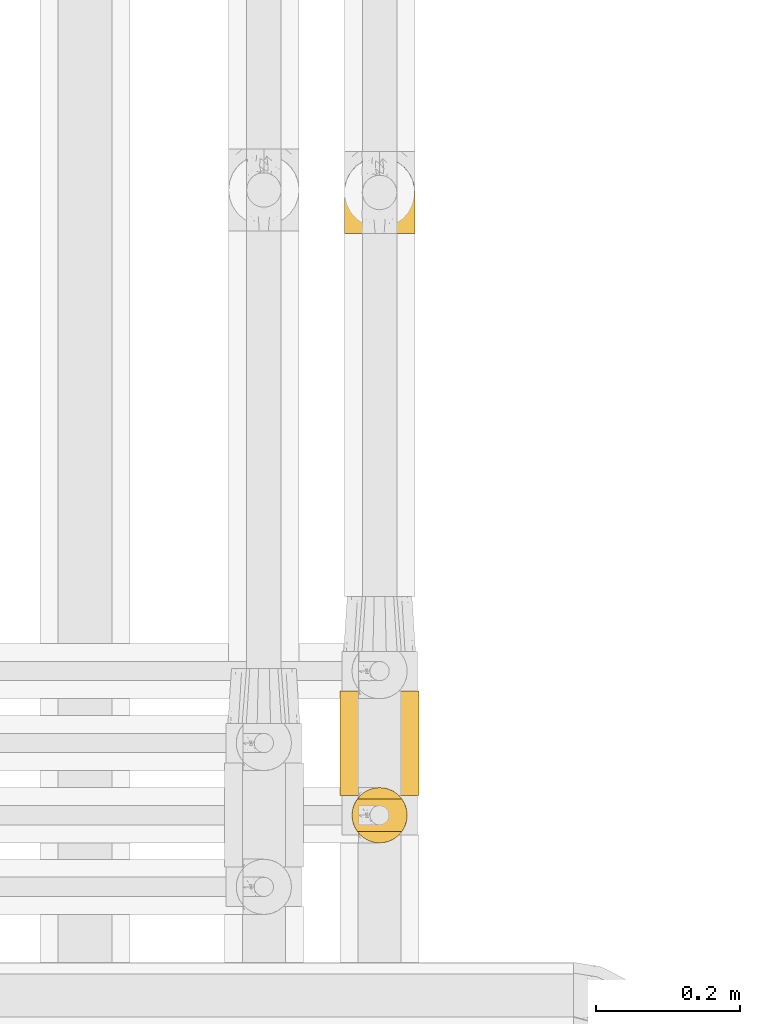
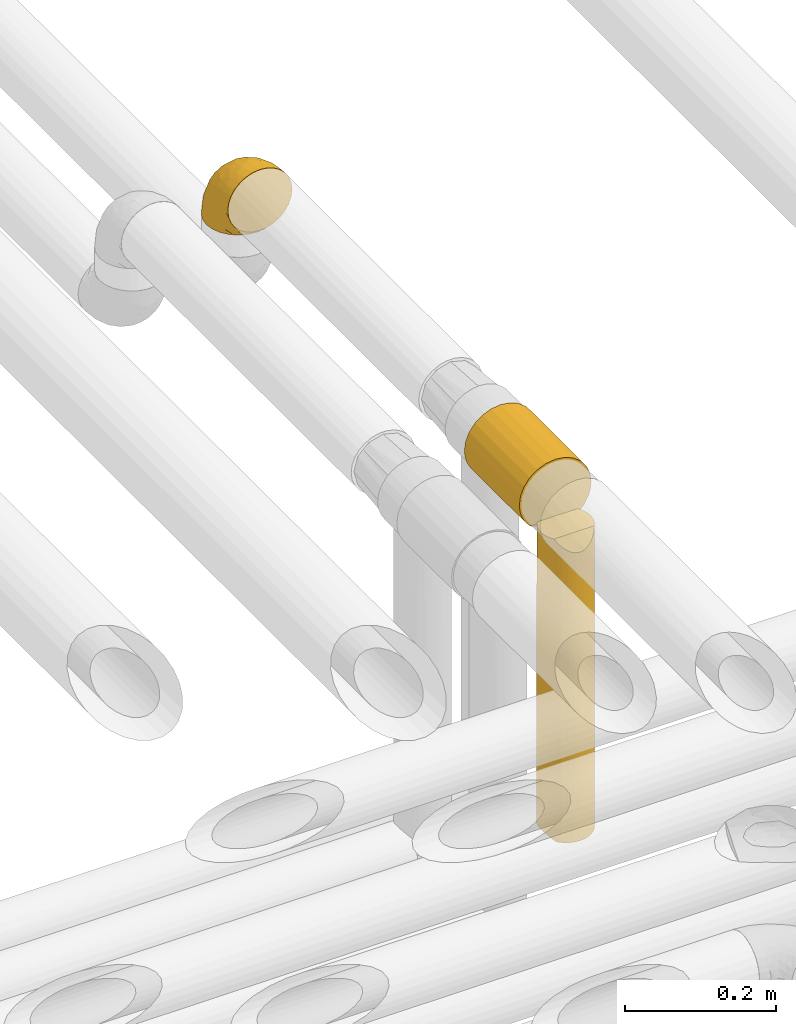
# One storey, part 347 of 827: 3 coverings.
"""IFC2X3 building model written with IfcOpenShell, lengths in millimetres."""

from ifc_helpers import new_model, entity, si_unit, converted_unit, derived_unit, direction, frame, origin, place, context, subcontext, project, spatial, faceted_brep, element, save


model = new_model("IFC2X3")

# Units and contexts
model_context = context("Model", 3, precision=0.01, world=origin(), true_north=direction((6.12303176911189e-17, 1.0)))
body_context = subcontext(model_context, "Body", "Model", "MODEL_VIEW")
ifc_project = project(units=[si_unit("LENGTHUNIT", "METRE", prefix="MILLI"), si_unit("AREAUNIT", "SQUARE_METRE"), si_unit("VOLUMEUNIT", "CUBIC_METRE"), converted_unit("PLANEANGLEUNIT", "DEGREE", entity("IfcRatioMeasure", 0.0174532925199433), si_unit("PLANEANGLEUNIT", "RADIAN"), dimensions=[0, 0, 0, 0, 0, 0, 0]), si_unit("MASSUNIT", "GRAM", prefix="KILO"), derived_unit("MASSDENSITYUNIT", [(si_unit("MASSUNIT", "GRAM", prefix="KILO"), 1), (si_unit("LENGTHUNIT", "METRE"), -3)]), derived_unit("MOMENTOFINERTIAUNIT", [(si_unit("LENGTHUNIT", "METRE"), 4)]), si_unit("TIMEUNIT", "SECOND"), si_unit("FREQUENCYUNIT", "HERTZ"), si_unit("THERMODYNAMICTEMPERATUREUNIT", "DEGREE_CELSIUS"), derived_unit("THERMALTRANSMITTANCEUNIT", [(si_unit("MASSUNIT", "GRAM", prefix="KILO"), 1), (si_unit("THERMODYNAMICTEMPERATUREUNIT", "KELVIN"), -1), (si_unit("TIMEUNIT", "SECOND"), -3)]), derived_unit("VOLUMETRICFLOWRATEUNIT", [(si_unit("LENGTHUNIT", "METRE"), 3), (si_unit("TIMEUNIT", "SECOND"), -1)]), derived_unit("MASSFLOWRATEUNIT", [(si_unit("MASSUNIT", "GRAM", prefix="KILO"), 1), (si_unit("TIMEUNIT", "SECOND"), -1)]), derived_unit("ROTATIONALFREQUENCYUNIT", [(si_unit("TIMEUNIT", "SECOND"), -1)]), si_unit("ELECTRICCURRENTUNIT", "AMPERE"), si_unit("ELECTRICVOLTAGEUNIT", "VOLT"), si_unit("POWERUNIT", "WATT"), si_unit("FORCEUNIT", "NEWTON", prefix="KILO"), si_unit("ILLUMINANCEUNIT", "LUX"), si_unit("LUMINOUSFLUXUNIT", "LUMEN"), si_unit("LUMINOUSINTENSITYUNIT", "CANDELA"), derived_unit("USERDEFINED", [(si_unit("MASSUNIT", "GRAM", prefix="KILO"), -1), (si_unit("LENGTHUNIT", "METRE"), -2), (si_unit("TIMEUNIT", "SECOND"), 3), (si_unit("LUMINOUSFLUXUNIT", "LUMEN"), 1)]), derived_unit("LINEARVELOCITYUNIT", [(si_unit("LENGTHUNIT", "METRE"), 1), (si_unit("TIMEUNIT", "SECOND"), -1)]), si_unit("PRESSUREUNIT", "PASCAL"), derived_unit("USERDEFINED", [(si_unit("LENGTHUNIT", "METRE"), -2), (si_unit("MASSUNIT", "GRAM", prefix="KILO"), 1), (si_unit("TIMEUNIT", "SECOND"), -2)]), derived_unit("LINEARFORCEUNIT", [(si_unit("MASSUNIT", "GRAM", prefix="KILO"), 1), (si_unit("LENGTHUNIT", "METRE"), 1), (si_unit("TIMEUNIT", "SECOND"), -2), (si_unit("LENGTHUNIT", "METRE"), -1)]), derived_unit("PLANARFORCEUNIT", [(si_unit("MASSUNIT", "GRAM", prefix="KILO"), 1), (si_unit("LENGTHUNIT", "METRE"), 1), (si_unit("TIMEUNIT", "SECOND"), -2), (si_unit("LENGTHUNIT", "METRE"), -2)])], contexts=[model_context])

# Site, building, storey
site_placement = place(None, origin())
site = spatial("IfcSite", under=ifc_project, at=site_placement, CompositionType="ELEMENT")
building_placement = place(site_placement, origin())
building = spatial("IfcBuilding", under=site, at=building_placement, CompositionType="ELEMENT")
storey_placement = place(building_placement, frame((0.0, 0.0, 28200.0)))
storey = spatial("IfcBuildingStorey", under=building, at=storey_placement, Name="08", CompositionType="ELEMENT", Elevation=28200.0)

# Coverings
covering_1_placement = place(storey_placement, frame((36578.9, 16196.89, 3491.4)))
element("IfcCovering", 1, at=covering_1_placement, inside=storey, Name=":ADSK_", ObjectType=":ADSK_", PredefinedType="INSULATION", context=body_context, shape_type="Brep", body=[
    faceted_brep([(99.9, 1.6, 58.6), (98.66, 1.6, 69.54), (95.02, 1.6, 79.93), (89.17, 1.6, 89.25), (81.38, 1.6, 97.03), (72.06, 1.6, 102.88), (61.68, 1.6, 106.51), (50.75, 1.6, 107.75), (39.8, 1.6, 106.51), (29.41, 1.6, 102.87), (20.09, 1.6, 97.02), (12.31, 1.6, 89.23), (6.46, 1.6, 79.91), (2.83, 1.6, 69.53), (1.6, 1.6, 58.6), (2.24, 1.6, 52.89), (2.83, 1.6, 47.65), (4.65, 1.6, 42.46), (6.47, 1.6, 37.26), (12.32, 1.6, 27.94), (20.11, 1.6, 20.16), (29.43, 1.6, 14.31), (39.81, 1.6, 10.68), (50.75, 1.6, 9.45), (61.69, 1.6, 10.68), (72.08, 1.6, 14.32), (81.4, 1.6, 20.17), (89.18, 1.6, 27.96), (95.03, 1.6, 37.28), (96.85, 1.6, 42.47), (98.66, 1.6, 47.66), (99.25, 1.6, 52.89), (99.57, 1.6, 55.75), (38.02, 11.12, 1.6), (26.17, 16.03, 1.6), (21.08, 19.94, 1.6), (15.99, 23.84, 1.6), (12.09, 28.93, 1.6), (8.18, 34.02, 1.6), (5.73, 39.95, 1.6), (3.27, 45.87, 1.6), (2.35, 52.86, 1.6), (1.97, 55.73, 1.6), (1.6, 58.6, 1.6), (3.27, 71.32, 1.6), (8.18, 83.17, 1.6), (15.99, 93.35, 1.6), (26.17, 101.16, 1.6), (38.02, 106.07, 1.6), (50.75, 107.75, 1.6), (63.47, 106.07, 1.6), (75.32, 101.16, 1.6), (85.5, 93.35, 1.6), (93.31, 83.17, 1.6), (98.22, 71.32, 1.6), (99.9, 58.6, 1.6), (99.14, 52.86, 1.6), (98.22, 45.87, 1.6), (95.77, 39.95, 1.6), (93.31, 34.02, 1.6), (89.4, 28.93, 1.6), (85.5, 23.84, 1.6), (80.41, 19.94, 1.6), (75.32, 16.03, 1.6), (63.47, 11.12, 1.6), (50.75, 9.45, 1.6), (59.31, 81.82, 69.96), (73.08, 84.02, 59.59), (63.72, 93.05, 51.96), (50.75, 102.55, 34.4), (58.64, 104.83, 23.37), (50.75, 105.83, 13.68), (76.74, 91.87, 41.52), (67.68, 101.74, 26.26), (78.92, 97.07, 20.18), (94.31, 38.45, 72.33), (98.76, 22.17, 65.88), (98.4, 42.04, 57.55), (94.57, 77.69, 23.76), (89.91, 75.76, 46.5), (96.32, 62.11, 46.57), (98.79, 66.08, 21.17), (99.9, 54.26, 23.41), (99.9, 55.35, 17.92), (99.9, 56.44, 12.43), (99.9, 56.98, 9.72), (99.9, 57.52, 7.01), (87.31, 87.84, 26.77), (95.61, 19.41, 76.59), (60.43, 48.89, 95.55), (65.24, 26.34, 102.57), (72.87, 44.55, 92.89), (99.9, 23.41, 54.26), (99.9, 28.03, 51.17), (99.9, 32.65, 48.08), (99.9, 37.28, 44.99), (99.9, 41.9, 41.9), (90.65, 20.6, 85.16), (63.14, 63.36, 85.97), (91.89, 62.21, 59.58), (75.25, 19.94, 99.5), (50.75, 13.68, 105.83), (82.18, 80.85, 53.59), (85.08, 66.53, 67.0), (76.93, 71.06, 71.56), (50.75, 63.99, 87.47), (50.75, 75.73, 75.73), (83.02, 26.77, 92.24), (99.9, 4.31, 58.06), (99.9, 7.01, 57.52), (99.9, 12.43, 56.44), (99.9, 17.92, 55.35), (87.13, 43.43, 81.33), (80.85, 56.23, 80.35), (99.17, 54.97, 39.44), (50.75, 34.4, 102.55), (99.9, 44.99, 37.28), (99.9, 48.08, 32.65), (99.9, 51.17, 28.03), (50.75, 87.47, 63.99), (67.61, 74.55, 74.55), (72.25, 60.86, 83.62), (50.75, 49.19, 95.01), (50.75, 95.01, 49.19), (98.69, 10.27, 46.96), (99.01, 48.79, 8.77), (98.79, 45.16, 18.28), (98.29, 44.99, 11.68), (68.51, 6.17, 11.79), (76.82, 7.65, 15.69), (98.54, 21.59, 42.49), (99.3, 19.96, 47.41), (83.57, 21.0, 7.94), (89.47, 27.2, 9.27), (75.76, 14.83, 7.98), (84.86, 19.7, 13.4), (75.89, 10.93, 13.04), (64.77, 9.63, 7.36), (90.83, 19.97, 23.46), (94.62, 21.13, 30.46), (90.37, 14.14, 26.54), (91.18, 30.2, 6.76), (88.65, 8.12, 26.46), (84.11, 9.93, 20.77), (91.75, 24.62, 20.68), (96.86, 11.87, 40.26), (50.75, 7.15, 7.15), (58.97, 5.32, 9.28), (98.37, 26.68, 38.78), (83.91, 13.92, 18.27), (97.52, 30.67, 31.78), (95.55, 36.65, 12.75), (98.76, 42.89, 22.96), (95.26, 34.04, 17.55), (98.04, 36.6, 27.63), (90.65, 26.41, 15.23), (93.51, 10.07, 33.25), (94.16, 15.83, 32.43), (99.1, 41.99, 27.9), (25.73, 14.83, 7.97), (10.84, 26.4, 15.22), (17.92, 21.01, 7.93), (16.64, 19.71, 13.38), (30.44, 5.72, 13.12), (2.95, 21.6, 42.49), (2.19, 19.96, 47.4), (1.6, 28.03, 51.17), (4.63, 11.87, 40.24), (17.39, 9.93, 20.76), (1.6, 58.06, 4.31), (1.6, 56.44, 12.43), (1.6, 57.52, 7.01), (12.86, 8.13, 26.44), (11.13, 14.15, 26.52), (3.2, 44.99, 11.68), (5.94, 36.65, 12.75), (12.02, 27.21, 9.27), (6.23, 34.04, 17.55), (10.31, 30.2, 6.76), (8.0, 10.06, 33.21), (7.34, 15.83, 32.41), (2.48, 48.79, 8.77), (2.73, 42.89, 22.96), (2.64, 45.38, 18.48), (1.6, 12.43, 56.44), (2.8, 10.28, 46.95), (36.71, 9.64, 7.36), (1.6, 55.35, 17.92), (1.6, 54.26, 23.41), (38.59, 6.05, 9.85), (1.6, 7.01, 57.52), (1.6, 9.72, 56.98), (1.6, 32.65, 48.08), (3.12, 26.68, 38.78), (17.59, 13.92, 18.25), (1.6, 37.28, 44.99), (3.98, 30.66, 31.74), (6.87, 21.14, 30.45), (3.45, 36.59, 27.63), (9.76, 24.6, 20.65), (1.6, 17.92, 55.35), (1.6, 23.41, 54.26), (25.62, 10.93, 13.03), (10.67, 19.97, 23.44), (2.39, 41.99, 27.9), (1.6, 48.08, 32.65), (1.6, 51.17, 28.03), (1.6, 44.99, 37.28), (1.6, 41.9, 41.9), (2.4, 55.26, 39.74), (42.85, 104.83, 23.37), (14.18, 87.84, 26.77), (11.56, 75.91, 46.18), (19.27, 80.84, 53.54), (24.75, 91.87, 41.53), (28.37, 83.98, 59.61), (5.95, 19.16, 76.79), (2.79, 22.37, 66.11), (2.71, 66.08, 21.17), (37.78, 93.05, 51.96), (33.81, 101.74, 26.26), (22.57, 97.07, 20.18), (6.92, 77.69, 23.76), (28.61, 44.55, 92.88), (36.24, 26.34, 102.57), (41.05, 48.9, 95.54), (24.55, 70.99, 71.63), (33.88, 74.55, 74.55), (7.11, 37.8, 72.51), (38.38, 63.4, 85.95), (42.18, 81.82, 69.96), (18.46, 26.77, 92.23), (10.84, 20.6, 85.15), (20.69, 56.15, 80.45), (29.27, 60.85, 83.65), (3.1, 42.06, 57.57), (9.18, 57.03, 63.68), (26.23, 19.94, 99.49), (14.34, 43.59, 81.23), (5.46, 62.61, 47.07), (16.39, 66.52, 66.99)], [[[0, 1, 2, 3, 4, 5, 6, 7, 8, 9, 10, 11, 12, 13, 14, 15, 16, 17, 18, 19, 20, 21, 22, 23, 24, 25, 26, 27, 28, 29, 30, 31, 32]], [[33, 34, 35, 36, 37, 38, 39, 40, 41, 42, 43, 44, 45, 46, 47, 48, 49, 50, 51, 52, 53, 54, 55, 56, 57, 58, 59, 60, 61, 62, 63, 64, 65]], [[66, 67, 68]], [[69, 70, 71]], [[68, 72, 73]], [[73, 72, 74]], [[75, 76, 77]], [[78, 79, 80]], [[51, 50, 73]], [[81, 82, 83, 84, 85, 86, 55]], [[52, 87, 53]], [[74, 52, 51]], [[2, 1, 88]], [[89, 90, 91]], [[77, 92, 93, 94, 95, 96]], [[55, 54, 81]], [[78, 53, 87]], [[5, 90, 6]], [[88, 76, 75]], [[97, 3, 2]], [[89, 91, 98]], [[99, 80, 79]], [[90, 5, 100]], [[74, 87, 52]], [[100, 5, 4]], [[90, 101, 6]], [[79, 102, 103]], [[102, 67, 104]], [[105, 98, 106]], [[107, 4, 3]], [[76, 0, 108, 109, 110, 111, 92]], [[107, 112, 113]], [[114, 77, 96]], [[89, 115, 90]], [[114, 96, 116, 117, 118, 82]], [[75, 97, 88]], [[119, 66, 68]], [[50, 71, 70]], [[100, 91, 90]], [[99, 77, 80]], [[102, 104, 103]], [[97, 107, 3]], [[80, 81, 78]], [[107, 97, 112]], [[68, 73, 70]], [[66, 98, 120]], [[78, 81, 54]], [[114, 81, 80]], [[53, 78, 54]], [[78, 87, 79]], [[102, 87, 72]], [[79, 103, 99]], [[4, 107, 100]], [[91, 100, 107]], [[88, 97, 2]], [[112, 97, 75]], [[99, 112, 75]], [[103, 104, 113]], [[91, 121, 98]], [[89, 105, 122, 115]], [[101, 90, 115]], [[101, 7, 6]], [[88, 1, 76]], [[0, 76, 1]], [[92, 77, 76]], [[73, 74, 51]], [[87, 74, 72]], [[81, 114, 82]], [[77, 114, 80]], [[87, 102, 79]], [[67, 102, 72]], [[68, 67, 72]], [[67, 120, 104]], [[120, 121, 104]], [[104, 121, 113]], [[121, 120, 98]], [[91, 107, 113]], [[91, 113, 121]], [[103, 113, 112]], [[66, 119, 106]], [[105, 89, 98]], [[68, 69, 123, 119]], [[98, 66, 106]], [[66, 120, 67]], [[50, 49, 71]], [[50, 70, 73]], [[112, 99, 103]], [[77, 99, 75]], [[69, 68, 70]], [[29, 124, 110]], [[84, 83, 125]], [[126, 82, 118]], [[59, 58, 127]], [[25, 128, 129]], [[130, 93, 131]], [[132, 62, 133]], [[134, 135, 136]], [[137, 65, 64]], [[64, 134, 137]], [[138, 139, 140]], [[111, 110, 124, 92]], [[134, 136, 137]], [[134, 64, 63]], [[141, 61, 60]], [[125, 58, 57]], [[142, 143, 140]], [[142, 26, 143]], [[127, 83, 82]], [[28, 124, 29]], [[108, 0, 32, 31, 30, 110, 109]], [[30, 29, 110]], [[135, 144, 138]], [[28, 145, 124]], [[57, 56, 55, 86, 85, 84]], [[146, 147, 23]], [[24, 23, 147]], [[25, 143, 26]], [[95, 94, 148]], [[24, 128, 25]], [[149, 138, 143]], [[124, 145, 131]], [[127, 58, 125]], [[150, 148, 139]], [[127, 126, 151]], [[151, 59, 127]], [[152, 151, 126]], [[153, 154, 155]], [[153, 133, 141]], [[145, 28, 27]], [[142, 156, 27]], [[157, 148, 130]], [[61, 133, 62]], [[134, 132, 135]], [[147, 128, 24]], [[65, 137, 146]], [[146, 137, 147]], [[128, 137, 136]], [[137, 128, 147]], [[128, 136, 129]], [[149, 129, 136]], [[25, 129, 143]], [[158, 152, 117]], [[152, 118, 117]], [[153, 151, 152]], [[158, 116, 154]], [[144, 150, 138]], [[153, 152, 158]], [[133, 153, 155]], [[133, 155, 132]], [[60, 151, 141]], [[135, 132, 155]], [[134, 63, 132]], [[144, 135, 155]], [[135, 138, 149]], [[155, 154, 144]], [[150, 154, 96]], [[154, 150, 144]], [[148, 94, 130]], [[82, 126, 127]], [[118, 152, 126]], [[150, 96, 95]], [[139, 148, 157]], [[150, 95, 148]], [[93, 92, 131]], [[130, 145, 156]], [[130, 94, 93]], [[84, 125, 57]], [[127, 125, 83]], [[140, 139, 157]], [[150, 139, 138]], [[140, 157, 142]], [[138, 140, 143]], [[156, 142, 157]], [[27, 26, 142]], [[130, 156, 157]], [[145, 27, 156]], [[132, 63, 62]], [[124, 131, 92]], [[130, 131, 145]], [[129, 149, 143]], [[135, 149, 136]], [[141, 133, 61]], [[60, 59, 151]], [[141, 151, 153]], [[116, 96, 154]], [[153, 158, 154]], [[158, 117, 116]], [[34, 33, 159]], [[160, 161, 162]], [[22, 21, 163]], [[164, 165, 166]], [[19, 18, 167]], [[168, 21, 20]], [[169, 43, 42, 41, 40, 170, 171]], [[172, 173, 168]], [[174, 38, 175]], [[176, 177, 178]], [[179, 164, 180]], [[40, 181, 170]], [[182, 183, 175]], [[17, 184, 185]], [[65, 146, 186]], [[187, 174, 188]], [[23, 22, 189]], [[174, 39, 38]], [[15, 14, 190, 191, 184, 16]], [[181, 40, 39]], [[192, 193, 164]], [[194, 163, 168]], [[33, 186, 159]], [[180, 173, 172]], [[195, 196, 193]], [[18, 185, 167]], [[173, 180, 197]], [[198, 199, 196]], [[200, 201, 185, 184]], [[184, 17, 16]], [[18, 17, 185]], [[202, 159, 186]], [[194, 168, 203]], [[189, 163, 202]], [[204, 205, 182]], [[187, 181, 174]], [[160, 177, 176]], [[206, 183, 182]], [[206, 182, 205]], [[201, 165, 185]], [[165, 164, 167]], [[172, 179, 180]], [[202, 194, 162]], [[176, 161, 160]], [[65, 186, 33]], [[163, 189, 22]], [[175, 177, 182]], [[174, 183, 188]], [[177, 198, 204]], [[199, 160, 162]], [[198, 207, 204]], [[175, 38, 37]], [[198, 177, 160]], [[178, 177, 175]], [[176, 35, 161]], [[34, 159, 161]], [[162, 161, 159]], [[202, 162, 159]], [[199, 162, 203]], [[196, 199, 203]], [[198, 160, 199]], [[193, 197, 180]], [[208, 198, 196]], [[188, 183, 206]], [[175, 183, 174]], [[193, 192, 195]], [[195, 208, 196]], [[197, 196, 203]], [[180, 164, 193]], [[168, 163, 21]], [[166, 165, 201]], [[166, 192, 164]], [[189, 202, 186]], [[186, 146, 189]], [[23, 189, 146]], [[174, 181, 39]], [[170, 181, 187]], [[196, 197, 193]], [[173, 203, 168]], [[203, 173, 197]], [[172, 168, 20]], [[20, 19, 172]], [[179, 172, 19]], [[19, 167, 179]], [[164, 179, 167]], [[35, 176, 36]], [[35, 34, 161]], [[185, 165, 167]], [[162, 194, 203]], [[163, 194, 202]], [[176, 178, 36]], [[37, 36, 178]], [[175, 37, 178]], [[177, 204, 182]], [[207, 198, 208]], [[207, 205, 204]], [[209, 188, 206, 205, 207, 208]], [[48, 210, 71]], [[211, 212, 213]], [[214, 213, 215]], [[216, 217, 13]], [[218, 43, 169, 171, 170, 187, 188]], [[219, 220, 214]], [[47, 46, 221]], [[210, 48, 220]], [[211, 222, 212]], [[222, 45, 44]], [[221, 220, 47]], [[47, 220, 48]], [[221, 211, 214]], [[223, 224, 225]], [[211, 46, 45]], [[226, 227, 215]], [[43, 218, 44]], [[217, 216, 228]], [[227, 229, 230]], [[14, 13, 217]], [[224, 9, 8]], [[10, 231, 11]], [[11, 232, 12]], [[233, 223, 234]], [[235, 208, 195, 192, 166, 201]], [[236, 235, 228]], [[222, 44, 218]], [[106, 230, 229]], [[224, 237, 9]], [[232, 238, 228]], [[9, 237, 10]], [[115, 224, 101]], [[239, 235, 236]], [[232, 11, 231]], [[223, 231, 237]], [[224, 8, 101]], [[223, 229, 234]], [[225, 115, 122, 105]], [[216, 12, 232]], [[209, 235, 239]], [[210, 219, 69]], [[219, 214, 215]], [[230, 119, 219]], [[209, 218, 188]], [[239, 212, 222]], [[239, 222, 218]], [[45, 222, 211]], [[236, 212, 239]], [[213, 212, 240]], [[223, 237, 224]], [[231, 10, 237]], [[238, 232, 231]], [[216, 232, 228]], [[233, 231, 223]], [[236, 238, 240]], [[115, 225, 224]], [[234, 229, 227]], [[8, 7, 101]], [[235, 209, 208]], [[218, 209, 239]], [[217, 228, 235]], [[13, 12, 216]], [[235, 201, 217]], [[217, 201, 200, 184, 191, 190, 14]], [[211, 221, 46]], [[220, 221, 214]], [[71, 210, 69]], [[71, 49, 48]], [[219, 210, 220]], [[226, 215, 213]], [[211, 213, 214]], [[226, 213, 240]], [[215, 227, 230]], [[233, 240, 238]], [[234, 227, 226]], [[233, 234, 226]], [[229, 223, 225]], [[240, 233, 226]], [[233, 238, 231]], [[225, 105, 229]], [[229, 105, 106]], [[106, 119, 230]], [[123, 69, 219, 119]], [[215, 230, 219]], [[238, 236, 228]], [[212, 236, 240]]]),
])
covering_2_placement = place(storey_placement, frame((36573.05, 15415.5, 3493.4)))
element("IfcCovering", 2, at=covering_2_placement, inside=storey, Name=":ADSK_", ObjectType=":ADSK_", PredefinedType="INSULATION", context=body_context, shape_type="Brep", body=[
    faceted_brep([(29.1, 147.04, 104.23), (42.36, 147.04, 109.72), (56.6, 147.04, 111.6), (70.83, 147.04, 109.72), (84.1, 147.04, 104.23), (95.49, 147.04, 95.49), (104.23, 147.04, 84.1), (109.72, 147.04, 70.83), (111.6, 147.04, 56.6), (110.51, 147.04, 45.71), (107.3, 147.04, 35.29), (102.09, 147.04, 25.69), (95.09, 147.04, 17.31), (18.1, 147.04, 17.31), (11.1, 147.04, 25.69), (5.89, 147.04, 35.29), (2.68, 147.04, 45.71), (1.6, 147.04, 56.6), (3.47, 147.04, 70.83), (8.96, 147.04, 84.1), (17.7, 147.04, 95.49), (56.6, 1.6, 111.6), (42.36, 1.6, 109.72), (29.1, 1.6, 104.23), (17.7, 1.6, 95.49), (8.96, 1.6, 84.1), (3.47, 1.6, 70.83), (1.6, 1.6, 56.6), (2.68, 1.6, 45.71), (5.89, 1.6, 35.29), (11.1, 1.6, 25.69), (18.1, 1.6, 17.31), (95.09, 1.6, 17.31), (102.09, 1.6, 25.69), (107.3, 1.6, 35.29), (110.51, 1.6, 45.71), (111.6, 1.6, 56.6), (109.72, 1.6, 70.83), (104.23, 1.6, 84.1), (95.49, 1.6, 95.49), (84.1, 1.6, 104.23), (70.83, 1.6, 109.72), (86.8, 6.27, 10.63), (86.8, 142.36, 10.63), (77.38, 9.74, 5.68), (67.19, 11.87, 2.62), (67.19, 136.76, 2.62), (77.38, 138.89, 5.68), (56.6, 12.6, 1.6), (56.6, 136.04, 1.6), (46.0, 11.87, 2.62), (46.0, 136.76, 2.62), (35.81, 9.74, 5.68), (26.39, 6.27, 10.63), (26.39, 142.36, 10.63), (35.81, 138.89, 5.68)], [[[0, 1, 2, 3, 4, 5, 6, 7, 8, 9, 10, 11, 12, 13, 14, 15, 16, 17, 18, 19, 20]], [[21, 22, 23, 24, 25, 26, 27, 28, 29, 30, 31, 32, 33, 34, 35, 36, 37, 38, 39, 40, 41]], [[36, 35, 9, 8]], [[34, 33, 11, 10]], [[35, 34, 10, 9]], [[33, 32, 12, 11]], [[32, 42, 43, 12]], [[44, 45, 46, 47]], [[42, 44, 47, 43]], [[45, 48, 49, 46]], [[48, 50, 51, 49]], [[52, 53, 54, 55]], [[50, 52, 55, 51]], [[13, 54, 53, 31]], [[15, 14, 30, 29]], [[16, 15, 29, 28]], [[17, 16, 28, 27]], [[31, 30, 14, 13]], [[18, 17, 27, 26]], [[19, 18, 26, 25]], [[25, 24, 20, 19]], [[1, 0, 23, 22]], [[2, 1, 22, 21]], [[24, 23, 0, 20]], [[3, 2, 21, 41]], [[4, 3, 41, 40]], [[40, 39, 5, 4]], [[7, 6, 38, 37]], [[8, 7, 37, 36]], [[39, 38, 6, 5]], [[43, 47, 46, 49, 51, 55, 54, 13, 12]], [[53, 52, 50, 48, 45, 44, 42, 32, 31]]]),
])
covering_3_placement = place(storey_placement, frame((36589.65, 15349.6, 3027.5)))
element("IfcCovering", 3, at=covering_3_placement, inside=storey, Name=":ADSK_", ObjectType=":ADSK_", PredefinedType="INSULATION", context=body_context, shape_type="Brep", body=[
    faceted_brep([(70.93, 17.25, 490.0), (75.01, 24.24, 490.0), (77.54, 31.93, 490.0), (78.4, 40.0, 490.0), (77.54, 48.06, 490.0), (75.01, 55.75, 490.0), (70.93, 62.75, 490.0), (9.06, 62.75, 490.0), (4.98, 55.75, 490.0), (2.45, 48.06, 490.0), (1.6, 40.0, 490.0), (2.45, 31.93, 490.0), (4.98, 24.24, 490.0), (9.06, 17.25, 490.0), (78.4, 40.0, 1.6), (77.09, 30.06, 1.6), (73.25, 20.8, 1.6), (67.15, 12.84, 1.6), (59.2, 6.74, 1.6), (49.93, 2.9, 1.6), (40.0, 1.6, 1.6), (31.79, 2.48, 1.6), (23.98, 5.09, 1.6), (16.91, 9.31, 1.6), (10.9, 14.94, 1.6), (10.9, 65.05, 1.6), (16.91, 70.68, 1.6), (23.98, 74.9, 1.6), (31.79, 77.51, 1.6), (40.0, 78.4, 1.6), (49.93, 77.09, 1.6), (59.2, 73.25, 1.6), (67.15, 67.15, 1.6), (73.25, 59.2, 1.6), (77.09, 49.93, 1.6), (2.2, 33.21, 10.29), (4.0, 26.63, 8.5), (2.97, 29.81, 243.75), (6.92, 20.48, 5.57), (8.88, 17.49, 236.9), (5.36, 23.41, 187.01), (40.0, 1.6, 251.26), (32.49, 2.34, 220.4), (1.6, 40.0, 250.45), (14.98, 10.86, 243.74), (12.97, 12.71, 483.52), (25.25, 4.54, 243.03), (40.0, 1.6, 467.64), (34.02, 2.06, 468.31), (1.6, 40.0, 227.27), (1.6, 40.0, 10.9), (28.2, 3.45, 470.29), (17.54, 8.84, 477.99), (22.66, 5.73, 473.55), (47.46, 2.33, 209.58), (54.76, 4.55, 223.03), (62.33, 8.76, 227.69), (76.48, 28.02, 255.92), (69.27, 15.14, 243.58), (57.33, 5.73, 473.55), (51.79, 3.45, 470.29), (45.97, 2.06, 468.31), (73.48, 21.19, 294.68), (67.02, 12.71, 483.52), (78.4, 40.0, 273.62), (62.45, 8.84, 477.99), (76.48, 51.97, 255.92), (69.27, 64.85, 243.58), (73.48, 58.8, 294.68), (45.97, 77.93, 468.31), (47.46, 77.66, 209.58), (40.0, 78.4, 251.27), (62.33, 71.23, 227.69), (67.02, 67.28, 483.52), (57.33, 74.26, 473.55), (54.76, 75.45, 223.03), (51.79, 76.54, 470.29), (40.0, 78.4, 467.64), (62.45, 71.15, 477.99), (19.86, 72.69, 235.42), (31.0, 77.33, 242.84), (10.73, 64.86, 251.9), (22.66, 74.26, 473.55), (28.2, 76.54, 470.29), (34.02, 77.93, 468.31), (17.54, 71.15, 477.99), (6.92, 59.51, 5.57), (4.0, 53.36, 8.5), (6.04, 57.94, 259.03), (2.2, 46.78, 10.29), (12.97, 67.28, 483.52), (2.97, 50.18, 243.75)], [[[0, 1, 2, 3, 4, 5, 6, 7, 8, 9, 10, 11, 12, 13]], [[14, 15, 16, 17, 18, 19, 20, 21, 22, 23, 24, 25, 26, 27, 28, 29, 30, 31, 32, 33, 34]], [[35, 36, 37]], [[38, 39, 40]], [[38, 24, 39]], [[12, 39, 13]], [[41, 42, 20]], [[37, 36, 40]], [[38, 40, 36]], [[11, 43, 37]], [[43, 35, 37]], [[12, 11, 37]], [[20, 42, 21]], [[37, 40, 12]], [[12, 40, 39]], [[39, 44, 45]], [[46, 44, 23]], [[41, 47, 48]], [[35, 43, 49, 50]], [[43, 11, 10]], [[46, 21, 42]], [[51, 42, 48]], [[51, 46, 42]], [[52, 45, 44]], [[45, 13, 39]], [[51, 53, 46]], [[46, 53, 52]], [[23, 22, 46]], [[46, 52, 44]], [[21, 46, 22]], [[44, 39, 24]], [[44, 24, 23]], [[48, 42, 41]], [[54, 19, 55]], [[54, 20, 19]], [[56, 55, 18]], [[19, 18, 55]], [[57, 2, 1]], [[17, 16, 58]], [[55, 56, 59]], [[55, 59, 60]], [[60, 61, 54]], [[58, 56, 17]], [[16, 57, 62]], [[63, 58, 0]], [[54, 55, 60]], [[16, 15, 57]], [[0, 62, 1]], [[16, 62, 58]], [[64, 3, 2]], [[41, 54, 61]], [[63, 65, 56]], [[58, 62, 0]], [[57, 1, 62]], [[17, 56, 18]], [[64, 57, 15]], [[64, 2, 57]], [[14, 64, 15]], [[63, 56, 58]], [[56, 65, 59]], [[20, 54, 41]], [[61, 47, 41]], [[64, 66, 4]], [[67, 68, 33]], [[69, 70, 71]], [[72, 32, 31]], [[71, 70, 29]], [[34, 64, 14]], [[33, 66, 34]], [[66, 5, 4]], [[5, 66, 68]], [[4, 3, 64]], [[73, 6, 67]], [[74, 75, 76]], [[6, 68, 67]], [[32, 72, 67]], [[77, 69, 71]], [[33, 68, 66]], [[76, 70, 69]], [[31, 30, 75]], [[72, 73, 67]], [[68, 6, 5]], [[72, 74, 78]], [[75, 30, 70]], [[33, 32, 67]], [[74, 72, 75]], [[64, 34, 66]], [[76, 75, 70]], [[31, 75, 72]], [[29, 70, 30]], [[73, 72, 78]], [[28, 71, 29]], [[27, 79, 80]], [[81, 26, 25]], [[80, 82, 83]], [[71, 28, 80]], [[84, 77, 71]], [[79, 82, 80]], [[82, 79, 85]], [[27, 26, 79]], [[80, 83, 84]], [[86, 81, 25]], [[85, 79, 81]], [[87, 88, 86]], [[89, 50, 49]], [[81, 90, 85]], [[71, 80, 84]], [[49, 9, 91]], [[89, 91, 87]], [[91, 88, 87]], [[27, 80, 28]], [[90, 81, 7]], [[81, 88, 7]], [[49, 91, 89]], [[86, 88, 81]], [[7, 88, 8]], [[9, 49, 43, 10]], [[8, 91, 9]], [[26, 81, 79]], [[91, 8, 88]], [[59, 65, 63, 0, 13, 45, 52, 53, 51, 48, 47, 61, 60]], [[82, 85, 90, 7, 6, 73, 78, 74, 76, 69, 77, 84, 83]], [[89, 87, 86, 25, 24, 38, 36, 35, 50]]]),
])

save(model, "model.ifc")
